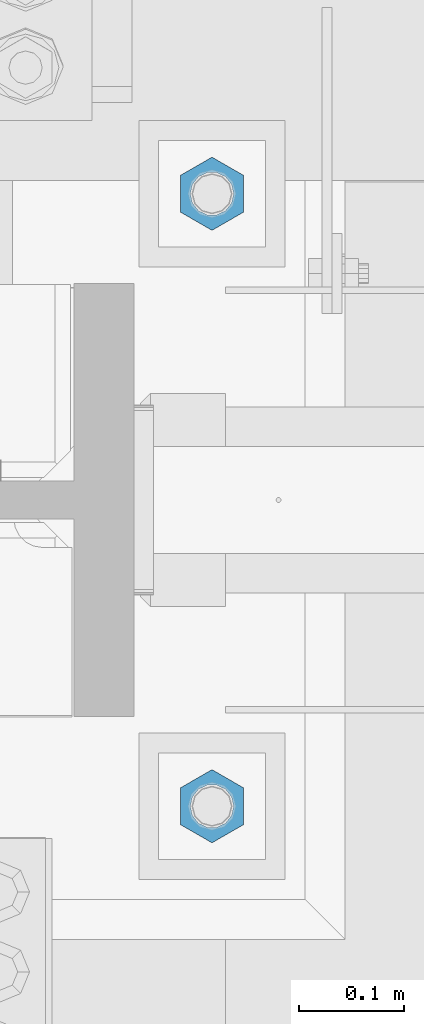
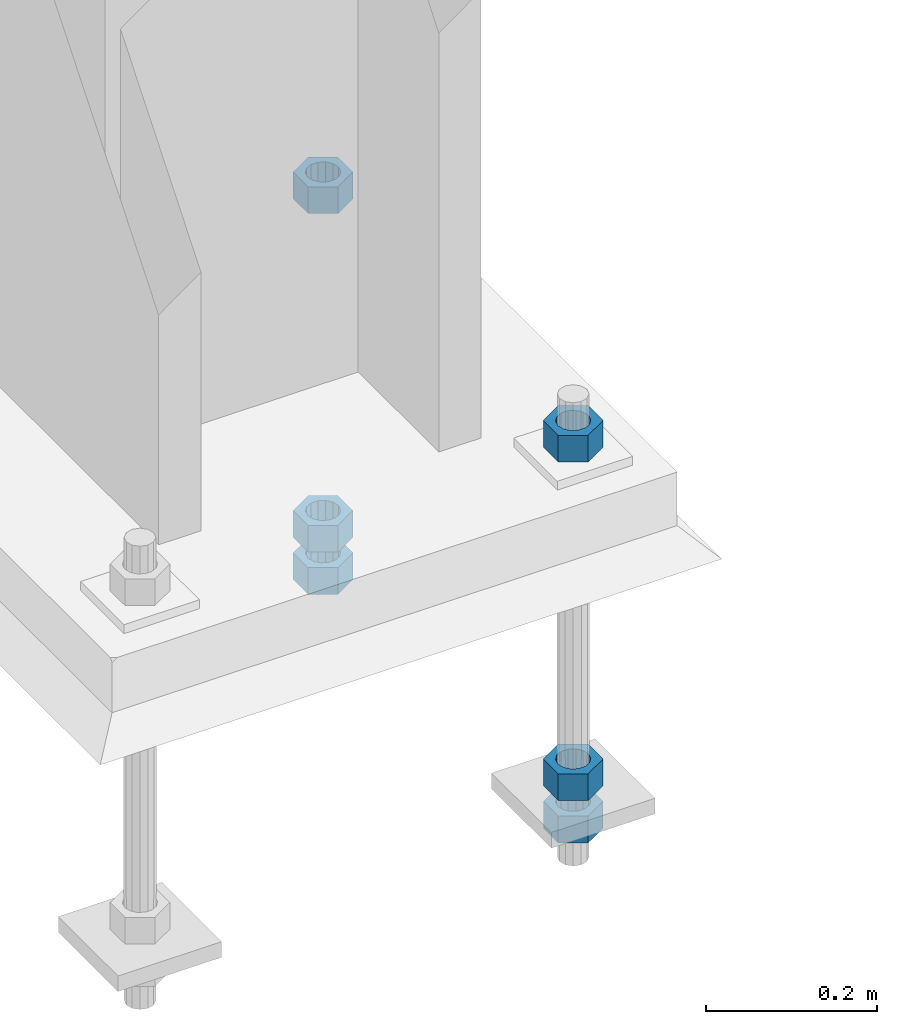
# One storey, part 1731 of 3843: 6 columns, 1 element without a shape of its own.
"""IFC2X3 building model written with IfcOpenShell, lengths in millimetres."""

import ifcopenshell
import ifcopenshell.guid

model = None  # the IFC model being written
_history = None  # IfcOwnerHistory: only IFC2X3 demands one
_inside = {}  # id of a spatial element -> (the spatial element, [elements in it])
_under = {}  # id of a project, library or spatial element -> (it, [spatial elements below it])
_declared = {}  # id of a project -> (the project, [libraries it declares])
_typed = {}  # id of a type object -> (the type object, [elements of that type])
_made_of = {}  # id of a material, layer set ... -> (it, [elements and type objects made of it])


def new_model(schema):
    """Start an empty IFC model of exactly this schema.

    Asked for "IFC4X3", IfcOpenShell would pick the latest addendum, in which some entities
    have other attributes; the version numbers below select the first issue.
    IFC2X3 requires an IfcOwnerHistory on every rooted entity: one is made here for all.
    """
    global model, _history
    if schema == "IFC4X3":
        model = ifcopenshell.file(schema_version=(4, 3, 0, 0))
    else:
        model = ifcopenshell.file(schema=schema)
    _inside.clear()
    _under.clear()
    _declared.clear()
    _typed.clear()
    _made_of.clear()
    _history = None
    if model.schema == "IFC2X3":
        org = make("IfcOrganization", Name="unknown")
        user = make(
            "IfcPersonAndOrganization",
            ThePerson=make("IfcPerson", FamilyName="unknown"),
            TheOrganization=org,
        )
        app = make(
            "IfcApplication",
            ApplicationDeveloper=org,
            Version="unknown",
            ApplicationFullName="unknown",
            ApplicationIdentifier="unknown",
        )
        _history = make(
            "IfcOwnerHistory",
            OwningUser=user,
            OwningApplication=app,
            ChangeAction="ADDED",
            CreationDate=0,
        )
    return model


def make(cls, **values):
    """One entity of the class cls with the attributes given. An attribute that is None is left unset."""
    return model.create_entity(
        cls, **{name: value for name, value in values.items() if value is not None}
    )


def rooted(cls, **values):
    """An entity with a GlobalId (a new one), such as an element, a storey or a relation."""
    return make(cls, GlobalId=ifcopenshell.guid.new(), OwnerHistory=_history, **values)


def si_unit(unit_type, name, prefix=None):
    """IfcSIUnit, for example si_unit("LENGTHUNIT", "METRE", prefix="MILLI")."""
    return make("IfcSIUnit", UnitType=unit_type, Prefix=prefix, Name=name)


def assignment(units):
    """IfcUnitAssignment: the units of a project."""
    return None if units is None else make("IfcUnitAssignment", Units=units)


def point(xyz):
    """IfcCartesianPoint."""
    return None if xyz is None else make("IfcCartesianPoint", Coordinates=xyz)


def direction(xyz):
    """IfcDirection."""
    return None if xyz is None else make("IfcDirection", DirectionRatios=xyz)


def frame(location, z_axis=None, x_axis=None):
    """IfcAxis2Placement3D, a coordinate frame: its origin and axes. An axis left out is left unset."""
    return make(
        "IfcAxis2Placement3D",
        Location=point(location),
        Axis=direction(z_axis),
        RefDirection=direction(x_axis),
    )


def origin_with_axes():
    """The frame at (0, 0, 0) with the z axis (0, 0, 1) and the x axis (1, 0, 0) written out."""
    return frame((0.0, 0.0, 0.0), z_axis=(0.0, 0.0, 1.0), x_axis=(1.0, 0.0, 0.0))


def place(relative_to, where):
    """IfcLocalPlacement: puts the frame where relative to a parent placement (None: the world)."""
    return make(
        "IfcLocalPlacement", PlacementRelTo=relative_to, RelativePlacement=where
    )


def context(
    kind, dimensions, precision=None, world=None, true_north=None, identifier=None
):
    """IfcGeometricRepresentationContext, for example the 3D "Model" context."""
    return make(
        "IfcGeometricRepresentationContext",
        ContextIdentifier=identifier,
        ContextType=kind,
        CoordinateSpaceDimension=dimensions,
        Precision=precision,
        WorldCoordinateSystem=world,
        TrueNorth=true_north,
    )


def subcontext(parent, identifier, kind, view, scale=None):
    """IfcGeometricRepresentationSubContext, for example "Body" below "Model"."""
    return make(
        "IfcGeometricRepresentationSubContext",
        ContextIdentifier=identifier,
        ContextType=kind,
        ParentContext=parent,
        TargetScale=scale,
        TargetView=view,
    )


def project(units=None, contexts=None):
    """IfcProject with its units and contexts."""
    return rooted(
        "IfcProject",
        Name="project",
        RepresentationContexts=contexts,
        UnitsInContext=assignment(units),
    )


def spatial(cls, under=None, at=None, **own):
    """A site, building, storey or space (cls), placed at a placement, below another one or the project."""
    s = rooted(cls, ObjectPlacement=at, **own)
    if under is not None:
        _under.setdefault(under.id(), (under, []))[1].append(s)
    return s


def faces_of(points, faces, orient=None, outer=None):
    """IfcFace entities. A face is a list of loops; a loop is a list of indices into points, from 0.

    orient and outer hold one flag for each loop. By default every Orientation is true, the
    first loop of a face is its IfcFaceOuterBound and the others are IfcFaceBound.
    """
    made = []
    for i, loops in enumerate(faces):
        bounds = []
        for j, loop in enumerate(loops):
            is_outer = j == 0 if outer is None else outer[i][j]
            bounds.append(
                make(
                    "IfcFaceOuterBound" if is_outer else "IfcFaceBound",
                    Bound=make("IfcPolyLoop", Polygon=[points[k] for k in loop]),
                    Orientation=True if orient is None else orient[i][j],
                )
            )
        made.append(make("IfcFace", Bounds=bounds))
    return made


def faceted_brep(points, faces, orient=None, outer=None, voids=None):
    """IfcFacetedBrep: a solid bounded by flat faces; with voids (closed shells), ...WithVoids."""
    shared = [point(p) for p in points]
    hull = make("IfcClosedShell", CfsFaces=faces_of(shared, faces, orient, outer))
    if voids is None:
        return make("IfcFacetedBrep", Outer=hull)
    return make(
        "IfcFacetedBrepWithVoids",
        Outer=hull,
        Voids=[
            make(cls, CfsFaces=faces_of(shared, fs, o, b)) for cls, fs, o, b in voids
        ],
    )


def shape(context_of_items, identifier, shape_type, items):
    """IfcShapeRepresentation: the items that make up one representation, for example the "Body"."""
    return make(
        "IfcShapeRepresentation",
        ContextOfItems=context_of_items,
        RepresentationIdentifier=identifier,
        RepresentationType=shape_type,
        Items=items,
    )


def material(Name=None, Category=None):
    """IfcMaterial."""
    return make("IfcMaterial", Name=Name, Category=Category)


def made_of(thing, what):
    """Note that an element or type object is made of a material, layer set ...; save() writes the relation."""
    if what is not None:
        _made_of.setdefault(what.id(), (what, []))[1].append(thing)
    return thing


def type_object(cls, material=None, **own):
    """A type object (cls), such as IfcWallType, which elements share."""
    return made_of(rooted(cls, **own), material)


def element(
    cls,
    number,
    at=None,
    inside=None,
    cuts=None,
    type_object=None,
    material=None,
    context=None,
    identifier="Body",
    shape_type=None,
    held_by="IfcProductDefinitionShape",
    body=None,
    shapes=None,
    **own,
):
    """One element of the class cls, such as IfcWall. Its Tag is "e" and its number.

    at: its placement. inside: the storey or other place that contains it. cuts: it is an
    opening in that element (IfcRelVoidsElement). A single representation is given by context,
    identifier, shape_type and body (its items); several are given by shapes. held_by: the class
    of the entity that holds the representations. save() writes the other relations.
    """
    e = rooted(cls, Tag="e%d" % number, ObjectPlacement=at, **own)
    if body is not None:
        shapes = [shape(context, identifier, shape_type, body)]
    if shapes is not None:
        e.Representation = make(held_by, Representations=shapes)
    if inside is not None:
        _inside.setdefault(inside.id(), (inside, []))[1].append(e)
    if cuts is not None:
        rooted(
            "IfcRelVoidsElement", RelatingBuildingElement=cuts, RelatedOpeningElement=e
        )
    if type_object is not None:
        _typed.setdefault(type_object.id(), (type_object, []))[1].append(e)
    return made_of(e, material)


def aggregate(whole, parts):
    """IfcRelAggregates: a whole, such as a stair, and the parts it consists of."""
    return rooted("IfcRelAggregates", RelatingObject=whole, RelatedObjects=parts)


def save(model, path):
    """Write the relations noted so far, then the file.

    IfcRelAggregates (storeys below a building ...), IfcRelContainedInSpatialStructure (elements
    in a storey), IfcRelDefinesByType, IfcRelAssociatesMaterial and IfcRelDeclares: one each for
    every whole, place, type object, material and project.
    """
    for whole, parts in _under.values():
        aggregate(whole, parts)
    for where, things in _inside.values():
        rooted(
            "IfcRelContainedInSpatialStructure",
            RelatedElements=things,
            RelatingStructure=where,
        )
    for kind, things in _typed.values():
        rooted("IfcRelDefinesByType", RelatedObjects=things, RelatingType=kind)
    for what, things in _made_of.values():
        rooted("IfcRelAssociatesMaterial", RelatedObjects=things, RelatingMaterial=what)
    for by, libraries in _declared.values():
        rooted("IfcRelDeclares", RelatingContext=by, RelatedDefinitions=libraries)
    model.write(path)


model = new_model("IFC2X3")

# Units and contexts
model_context = context("Model", 3, precision=1e-05, world=origin_with_axes())
body_context = subcontext(model_context, "Body", "Model", "MODEL_VIEW")
ifc_project = project(units=[si_unit("LENGTHUNIT", "METRE", prefix="MILLI"), si_unit("AREAUNIT", "SQUARE_METRE"), si_unit("VOLUMEUNIT", "CUBIC_METRE"), si_unit("MASSUNIT", "GRAM", prefix="KILO"), si_unit("TIMEUNIT", "SECOND"), si_unit("PLANEANGLEUNIT", "RADIAN"), si_unit("SOLIDANGLEUNIT", "STERADIAN"), si_unit("THERMODYNAMICTEMPERATUREUNIT", "DEGREE_CELSIUS"), si_unit("LUMINOUSINTENSITYUNIT", "LUMEN")], contexts=[model_context])

# Site, building, storey
site_placement = place(None, origin_with_axes())
site = spatial("IfcSite", under=ifc_project, at=site_placement, CompositionType="ELEMENT")
building_placement = place(site_placement, origin_with_axes())
building = spatial("IfcBuilding", under=site, at=building_placement, Name="Undefined", CompositionType="ELEMENT")
storey_placement = place(building_placement, origin_with_axes())
storey = spatial("IfcBuildingStorey", under=building, at=storey_placement, Name="Undefined", CompositionType="ELEMENT", Elevation=0.0)

# Assembly, columns
assembly_placement = place(storey_placement, origin_with_axes())
assembly = element("IfcElementAssembly", 1, at=assembly_placement, inside=storey, Name="TEMPLATE", AssemblyPlace="NOTDEFINED", PredefinedType="RIGID_FRAME")
ifc_material = material(Name="STEEL/A572-50")
column_type = type_object("IfcColumnType", Name="1-1/2_HEAVY_HEX_NUT", PredefinedType="NOTDEFINED")
column_1_placement = place(assembly_placement, frame((85940.9, 28422.6, 29705.3), z_axis=(1.0, 0.0, 0.0), x_axis=(0.0, 0.0, -1.0)))
column_1 = element("IfcColumn", 2, at=column_1_placement, type_object=column_type, material=ifc_material, Name="NUT", ObjectType="1-1/2_HEAVY_HEX_NUT", context=body_context, shape_type="Brep", body=[
    faceted_brep([(0.0, -34.9199981689453, 0.0), (0.0, -17.4599990844727, -30.25), (38.0999999999985, -17.4599990844727, -30.25), (38.0999999999985, -34.9199981689453, 0.0), (0.0, 17.4599990844727, -30.25), (38.0999999999985, 17.4599990844727, -30.25), (0.0, 34.9199981689453, 0.0), (38.0999999999985, 34.9199981689453, 0.0), (0.0, 17.4599990844727, 30.25), (38.0999999999985, 17.4599990844727, 30.25), (0.0, -17.4599990844727, 30.25), (38.0999999999985, -17.4599990844727, 30.25), (0.0, 0.0, 20.6399993896484), (0.0, 8.9553601105581, 18.5959968835959), (38.0999999999985, 8.9553601105581, 18.5959968835959), (38.0999999999985, 0.0, 20.6399993896484), (0.0, 16.1370013209525, 12.8688291298167), (38.0999999999985, 16.1370013209525, 12.8688291298167), (0.0, 20.1225115123816, 4.59283194104501), (38.0999999999985, 20.1225115123816, 4.59283194104501), (0.0, 20.1225115123816, -4.59283194104501), (38.0999999999985, 20.1225115123816, -4.59283194104501), (0.0, 16.1370013209525, -12.8688291298167), (38.0999999999985, 16.1370013209525, -12.8688291298167), (0.0, 8.9553601105581, -18.5959968835959), (38.0999999999985, 8.9553601105581, -18.5959968835959), (0.0, 0.0, -20.6399993896484), (38.0999999999985, 0.0, -20.6399993896484), (0.0, -8.9553601105581, -18.5959968835959), (38.0999999999985, -8.9553601105581, -18.5959968835959), (0.0, -16.1370013209525, -12.8688291298167), (38.0999999999985, -16.1370013209525, -12.8688291298167), (0.0, -20.1225115123816, -4.59283194104501), (38.0999999999985, -20.1225115123816, -4.59283194104501), (0.0, -20.1225115123816, 4.59283194104501), (38.0999999999985, -20.1225115123816, 4.59283194104501), (0.0, -16.1370013209525, 12.8688291298167), (38.0999999999985, -16.1370013209525, 12.8688291298167), (0.0, -8.9553601105581, 18.5959968835959), (38.0999999999985, -8.9553601105581, 18.5959968835959)], [[[0, 1, 2, 3]], [[1, 4, 5, 2]], [[4, 6, 7, 5]], [[6, 8, 9, 7]], [[8, 10, 11, 9]], [[10, 0, 3, 11]], [[12, 13, 14, 15]], [[13, 16, 17, 14]], [[16, 18, 19, 17]], [[18, 20, 21, 19]], [[20, 22, 23, 21]], [[22, 24, 25, 23]], [[24, 26, 27, 25]], [[26, 28, 29, 27]], [[28, 30, 31, 29]], [[30, 32, 33, 31]], [[32, 34, 35, 33]], [[34, 36, 37, 35]], [[36, 38, 39, 37]], [[38, 12, 15, 39]], [[5, 7, 9, 11, 3, 2], [17, 19, 21, 23, 25, 27, 29, 31, 33, 35, 37, 39, 15, 14]], [[10, 8, 6, 4, 1, 0], [38, 36, 34, 32, 30, 28, 26, 24, 22, 20, 18, 16, 13, 12]]]),
])
column_2_placement = place(assembly_placement, frame((85940.9, 29006.8, 29705.3), z_axis=(-1.0, 0.0, 0.0), x_axis=(0.0, 0.0, -1.0)))
column_2 = element("IfcColumn", 3, at=column_2_placement, type_object=column_type, material=ifc_material, Name="NUT", ObjectType="1-1/2_HEAVY_HEX_NUT", context=body_context, shape_type="Brep", body=[
    faceted_brep([(0.0, -34.9199981689453, 0.0), (0.0, -17.4599990844727, -30.25), (38.0999999999985, -17.4599990844727, -30.25), (38.0999999999985, -34.9199981689453, 0.0), (0.0, 17.4599990844727, -30.25), (38.0999999999985, 17.4599990844727, -30.25), (0.0, 34.9199981689453, 0.0), (38.0999999999985, 34.9199981689453, 0.0), (0.0, 17.4599990844727, 30.25), (38.0999999999985, 17.4599990844727, 30.25), (0.0, -17.4599990844727, 30.25), (38.0999999999985, -17.4599990844727, 30.25), (0.0, 0.0, 20.6399993896484), (0.0, 8.9553601105581, 18.5959968835959), (38.0999999999985, 8.9553601105581, 18.5959968835959), (38.0999999999985, 0.0, 20.6399993896484), (0.0, 16.1370013209525, 12.8688291298167), (38.0999999999985, 16.1370013209525, 12.8688291298167), (0.0, 20.1225115123816, 4.59283194104501), (38.0999999999985, 20.1225115123816, 4.59283194104501), (0.0, 20.1225115123816, -4.59283194104501), (38.0999999999985, 20.1225115123816, -4.59283194104501), (0.0, 16.1370013209525, -12.8688291298167), (38.0999999999985, 16.1370013209525, -12.8688291298167), (0.0, 8.9553601105581, -18.5959968835959), (38.0999999999985, 8.9553601105581, -18.5959968835959), (0.0, 0.0, -20.6399993896484), (38.0999999999985, 0.0, -20.6399993896484), (0.0, -8.9553601105581, -18.5959968835959), (38.0999999999985, -8.9553601105581, -18.5959968835959), (0.0, -16.1370013209525, -12.8688291298167), (38.0999999999985, -16.1370013209525, -12.8688291298167), (0.0, -20.1225115123816, -4.59283194104501), (38.0999999999985, -20.1225115123816, -4.59283194104501), (0.0, -20.1225115123816, 4.59283194104501), (38.0999999999985, -20.1225115123816, 4.59283194104501), (0.0, -16.1370013209525, 12.8688291298167), (38.0999999999985, -16.1370013209525, 12.8688291298167), (0.0, -8.9553601105581, 18.5959968835959), (38.0999999999985, -8.9553601105581, 18.5959968835959)], [[[0, 1, 2, 3]], [[1, 4, 5, 2]], [[4, 6, 7, 5]], [[6, 8, 9, 7]], [[8, 10, 11, 9]], [[10, 0, 3, 11]], [[12, 13, 14, 15]], [[13, 16, 17, 14]], [[16, 18, 19, 17]], [[18, 20, 21, 19]], [[20, 22, 23, 21]], [[22, 24, 25, 23]], [[24, 26, 27, 25]], [[26, 28, 29, 27]], [[28, 30, 31, 29]], [[30, 32, 33, 31]], [[32, 34, 35, 33]], [[34, 36, 37, 35]], [[36, 38, 39, 37]], [[38, 12, 15, 39]], [[5, 7, 9, 11, 3, 2], [17, 19, 21, 23, 25, 27, 29, 31, 33, 35, 37, 39, 15, 14]], [[10, 8, 6, 4, 1, 0], [38, 36, 34, 32, 30, 28, 26, 24, 22, 20, 18, 16, 13, 12]]]),
])
column_3_placement = place(assembly_placement, frame((85940.9, 28422.6, 30187.9), z_axis=(1.0, 0.0, 0.0), x_axis=(0.0, 0.0, -1.0)))
column_3 = element("IfcColumn", 4, at=column_3_placement, type_object=column_type, material=ifc_material, Name="NUT", ObjectType="1-1/2_HEAVY_HEX_NUT", context=body_context, shape_type="Brep", body=[
    faceted_brep([(0.0, -34.9199981689453, 0.0), (0.0, -17.4599990844727, -30.25), (38.0999999999985, -17.4599990844727, -30.25), (38.0999999999985, -34.9199981689453, 0.0), (0.0, 17.4599990844727, -30.25), (38.0999999999985, 17.4599990844727, -30.25), (0.0, 34.9199981689453, 0.0), (38.0999999999985, 34.9199981689453, 0.0), (0.0, 17.4599990844727, 30.25), (38.0999999999985, 17.4599990844727, 30.25), (0.0, -17.4599990844727, 30.25), (38.0999999999985, -17.4599990844727, 30.25), (0.0, 0.0, 20.6399993896484), (0.0, 8.9553601105581, 18.5959968835959), (38.0999999999985, 8.9553601105581, 18.5959968835959), (38.0999999999985, 0.0, 20.6399993896484), (0.0, 16.1370013209525, 12.8688291298167), (38.0999999999985, 16.1370013209525, 12.8688291298167), (0.0, 20.1225115123816, 4.59283194104501), (38.0999999999985, 20.1225115123816, 4.59283194104501), (0.0, 20.1225115123816, -4.59283194104501), (38.0999999999985, 20.1225115123816, -4.59283194104501), (0.0, 16.1370013209525, -12.8688291298167), (38.0999999999985, 16.1370013209525, -12.8688291298167), (0.0, 8.9553601105581, -18.5959968835959), (38.0999999999985, 8.9553601105581, -18.5959968835959), (0.0, 0.0, -20.6399993896484), (38.0999999999985, 0.0, -20.6399993896484), (0.0, -8.9553601105581, -18.5959968835959), (38.0999999999985, -8.9553601105581, -18.5959968835959), (0.0, -16.1370013209525, -12.8688291298167), (38.0999999999985, -16.1370013209525, -12.8688291298167), (0.0, -20.1225115123816, -4.59283194104501), (38.0999999999985, -20.1225115123816, -4.59283194104501), (0.0, -20.1225115123816, 4.59283194104501), (38.0999999999985, -20.1225115123816, 4.59283194104501), (0.0, -16.1370013209525, 12.8688291298167), (38.0999999999985, -16.1370013209525, 12.8688291298167), (0.0, -8.9553601105581, 18.5959968835959), (38.0999999999985, -8.9553601105581, 18.5959968835959)], [[[0, 1, 2, 3]], [[1, 4, 5, 2]], [[4, 6, 7, 5]], [[6, 8, 9, 7]], [[8, 10, 11, 9]], [[10, 0, 3, 11]], [[12, 13, 14, 15]], [[13, 16, 17, 14]], [[16, 18, 19, 17]], [[18, 20, 21, 19]], [[20, 22, 23, 21]], [[22, 24, 25, 23]], [[24, 26, 27, 25]], [[26, 28, 29, 27]], [[28, 30, 31, 29]], [[30, 32, 33, 31]], [[32, 34, 35, 33]], [[34, 36, 37, 35]], [[36, 38, 39, 37]], [[38, 12, 15, 39]], [[5, 7, 9, 11, 3, 2], [17, 19, 21, 23, 25, 27, 29, 31, 33, 35, 37, 39, 15, 14]], [[10, 8, 6, 4, 1, 0], [38, 36, 34, 32, 30, 28, 26, 24, 22, 20, 18, 16, 13, 12]]]),
])
column_4_placement = place(assembly_placement, frame((85940.9, 28422.6, 29644.975), z_axis=(1.0, 0.0, 0.0), x_axis=(0.0, 0.0, -1.0)))
column_4 = element("IfcColumn", 5, at=column_4_placement, type_object=column_type, material=ifc_material, Name="NUT", ObjectType="1-1/2_HEAVY_HEX_NUT", context=body_context, shape_type="Brep", body=[
    faceted_brep([(0.0, -34.9199981689453, 0.0), (0.0, -17.4599990844727, -30.25), (38.0999999999985, -17.4599990844727, -30.25), (38.0999999999985, -34.9199981689453, 0.0), (0.0, 17.4599990844727, -30.25), (38.0999999999985, 17.4599990844727, -30.25), (0.0, 34.9199981689453, 0.0), (38.0999999999985, 34.9199981689453, 0.0), (0.0, 17.4599990844727, 30.25), (38.0999999999985, 17.4599990844727, 30.25), (0.0, -17.4599990844727, 30.25), (38.0999999999985, -17.4599990844727, 30.25), (0.0, 0.0, 20.6399993896484), (0.0, 8.9553601105581, 18.5959968835959), (38.0999999999985, 8.9553601105581, 18.5959968835959), (38.0999999999985, 0.0, 20.6399993896484), (0.0, 16.1370013209525, 12.8688291298167), (38.0999999999985, 16.1370013209525, 12.8688291298167), (0.0, 20.1225115123816, 4.59283194104501), (38.0999999999985, 20.1225115123816, 4.59283194104501), (0.0, 20.1225115123816, -4.59283194104501), (38.0999999999985, 20.1225115123816, -4.59283194104501), (0.0, 16.1370013209525, -12.8688291298167), (38.0999999999985, 16.1370013209525, -12.8688291298167), (0.0, 8.9553601105581, -18.5959968835959), (38.0999999999985, 8.9553601105581, -18.5959968835959), (0.0, 0.0, -20.6399993896484), (38.0999999999985, 0.0, -20.6399993896484), (0.0, -8.9553601105581, -18.5959968835959), (38.0999999999985, -8.9553601105581, -18.5959968835959), (0.0, -16.1370013209525, -12.8688291298167), (38.0999999999985, -16.1370013209525, -12.8688291298167), (0.0, -20.1225115123816, -4.59283194104501), (38.0999999999985, -20.1225115123816, -4.59283194104501), (0.0, -20.1225115123816, 4.59283194104501), (38.0999999999985, -20.1225115123816, 4.59283194104501), (0.0, -16.1370013209525, 12.8688291298167), (38.0999999999985, -16.1370013209525, 12.8688291298167), (0.0, -8.9553601105581, 18.5959968835959), (38.0999999999985, -8.9553601105581, 18.5959968835959)], [[[0, 1, 2, 3]], [[1, 4, 5, 2]], [[4, 6, 7, 5]], [[6, 8, 9, 7]], [[8, 10, 11, 9]], [[10, 0, 3, 11]], [[12, 13, 14, 15]], [[13, 16, 17, 14]], [[16, 18, 19, 17]], [[18, 20, 21, 19]], [[20, 22, 23, 21]], [[22, 24, 25, 23]], [[24, 26, 27, 25]], [[26, 28, 29, 27]], [[28, 30, 31, 29]], [[30, 32, 33, 31]], [[32, 34, 35, 33]], [[34, 36, 37, 35]], [[36, 38, 39, 37]], [[38, 12, 15, 39]], [[5, 7, 9, 11, 3, 2], [17, 19, 21, 23, 25, 27, 29, 31, 33, 35, 37, 39, 15, 14]], [[10, 8, 6, 4, 1, 0], [38, 36, 34, 32, 30, 28, 26, 24, 22, 20, 18, 16, 13, 12]]]),
])
column_5_placement = place(assembly_placement, frame((85940.9, 29006.8, 30187.9), z_axis=(-1.0, 0.0, 0.0), x_axis=(0.0, 0.0, -1.0)))
column_5 = element("IfcColumn", 6, at=column_5_placement, type_object=column_type, material=ifc_material, Name="NUT", ObjectType="1-1/2_HEAVY_HEX_NUT", context=body_context, shape_type="Brep", body=[
    faceted_brep([(0.0, -34.9199981689453, 0.0), (0.0, -17.4599990844727, -30.25), (38.0999999999985, -17.4599990844727, -30.25), (38.0999999999985, -34.9199981689453, 0.0), (0.0, 17.4599990844727, -30.25), (38.0999999999985, 17.4599990844727, -30.25), (0.0, 34.9199981689453, 0.0), (38.0999999999985, 34.9199981689453, 0.0), (0.0, 17.4599990844727, 30.25), (38.0999999999985, 17.4599990844727, 30.25), (0.0, -17.4599990844727, 30.25), (38.0999999999985, -17.4599990844727, 30.25), (0.0, 0.0, 20.6399993896484), (0.0, 8.9553601105581, 18.5959968835959), (38.0999999999985, 8.9553601105581, 18.5959968835959), (38.0999999999985, 0.0, 20.6399993896484), (0.0, 16.1370013209525, 12.8688291298167), (38.0999999999985, 16.1370013209525, 12.8688291298167), (0.0, 20.1225115123816, 4.59283194104501), (38.0999999999985, 20.1225115123816, 4.59283194104501), (0.0, 20.1225115123816, -4.59283194104501), (38.0999999999985, 20.1225115123816, -4.59283194104501), (0.0, 16.1370013209525, -12.8688291298167), (38.0999999999985, 16.1370013209525, -12.8688291298167), (0.0, 8.9553601105581, -18.5959968835959), (38.0999999999985, 8.9553601105581, -18.5959968835959), (0.0, 0.0, -20.6399993896484), (38.0999999999985, 0.0, -20.6399993896484), (0.0, -8.9553601105581, -18.5959968835959), (38.0999999999985, -8.9553601105581, -18.5959968835959), (0.0, -16.1370013209525, -12.8688291298167), (38.0999999999985, -16.1370013209525, -12.8688291298167), (0.0, -20.1225115123816, -4.59283194104501), (38.0999999999985, -20.1225115123816, -4.59283194104501), (0.0, -20.1225115123816, 4.59283194104501), (38.0999999999985, -20.1225115123816, 4.59283194104501), (0.0, -16.1370013209525, 12.8688291298167), (38.0999999999985, -16.1370013209525, 12.8688291298167), (0.0, -8.9553601105581, 18.5959968835959), (38.0999999999985, -8.9553601105581, 18.5959968835959)], [[[0, 1, 2, 3]], [[1, 4, 5, 2]], [[4, 6, 7, 5]], [[6, 8, 9, 7]], [[8, 10, 11, 9]], [[10, 0, 3, 11]], [[12, 13, 14, 15]], [[13, 16, 17, 14]], [[16, 18, 19, 17]], [[18, 20, 21, 19]], [[20, 22, 23, 21]], [[22, 24, 25, 23]], [[24, 26, 27, 25]], [[26, 28, 29, 27]], [[28, 30, 31, 29]], [[30, 32, 33, 31]], [[32, 34, 35, 33]], [[34, 36, 37, 35]], [[36, 38, 39, 37]], [[38, 12, 15, 39]], [[5, 7, 9, 11, 3, 2], [17, 19, 21, 23, 25, 27, 29, 31, 33, 35, 37, 39, 15, 14]], [[10, 8, 6, 4, 1, 0], [38, 36, 34, 32, 30, 28, 26, 24, 22, 20, 18, 16, 13, 12]]]),
])
column_6_placement = place(assembly_placement, frame((85940.9, 29006.8, 29644.975), z_axis=(-1.0, 0.0, 0.0), x_axis=(0.0, 0.0, -1.0)))
column_6 = element("IfcColumn", 7, at=column_6_placement, type_object=column_type, material=ifc_material, Name="NUT", ObjectType="1-1/2_HEAVY_HEX_NUT", context=body_context, shape_type="Brep", body=[
    faceted_brep([(0.0, -34.9199981689453, 0.0), (0.0, -17.4599990844727, -30.25), (38.0999999999985, -17.4599990844727, -30.25), (38.0999999999985, -34.9199981689453, 0.0), (0.0, 17.4599990844727, -30.25), (38.0999999999985, 17.4599990844727, -30.25), (0.0, 34.9199981689453, 0.0), (38.0999999999985, 34.9199981689453, 0.0), (0.0, 17.4599990844727, 30.25), (38.0999999999985, 17.4599990844727, 30.25), (0.0, -17.4599990844727, 30.25), (38.0999999999985, -17.4599990844727, 30.25), (0.0, 0.0, 20.6399993896484), (0.0, 8.9553601105581, 18.5959968835959), (38.0999999999985, 8.9553601105581, 18.5959968835959), (38.0999999999985, 0.0, 20.6399993896484), (0.0, 16.1370013209525, 12.8688291298167), (38.0999999999985, 16.1370013209525, 12.8688291298167), (0.0, 20.1225115123816, 4.59283194104501), (38.0999999999985, 20.1225115123816, 4.59283194104501), (0.0, 20.1225115123816, -4.59283194104501), (38.0999999999985, 20.1225115123816, -4.59283194104501), (0.0, 16.1370013209525, -12.8688291298167), (38.0999999999985, 16.1370013209525, -12.8688291298167), (0.0, 8.9553601105581, -18.5959968835959), (38.0999999999985, 8.9553601105581, -18.5959968835959), (0.0, 0.0, -20.6399993896484), (38.0999999999985, 0.0, -20.6399993896484), (0.0, -8.9553601105581, -18.5959968835959), (38.0999999999985, -8.9553601105581, -18.5959968835959), (0.0, -16.1370013209525, -12.8688291298167), (38.0999999999985, -16.1370013209525, -12.8688291298167), (0.0, -20.1225115123816, -4.59283194104501), (38.0999999999985, -20.1225115123816, -4.59283194104501), (0.0, -20.1225115123816, 4.59283194104501), (38.0999999999985, -20.1225115123816, 4.59283194104501), (0.0, -16.1370013209525, 12.8688291298167), (38.0999999999985, -16.1370013209525, 12.8688291298167), (0.0, -8.9553601105581, 18.5959968835959), (38.0999999999985, -8.9553601105581, 18.5959968835959)], [[[0, 1, 2, 3]], [[1, 4, 5, 2]], [[4, 6, 7, 5]], [[6, 8, 9, 7]], [[8, 10, 11, 9]], [[10, 0, 3, 11]], [[12, 13, 14, 15]], [[13, 16, 17, 14]], [[16, 18, 19, 17]], [[18, 20, 21, 19]], [[20, 22, 23, 21]], [[22, 24, 25, 23]], [[24, 26, 27, 25]], [[26, 28, 29, 27]], [[28, 30, 31, 29]], [[30, 32, 33, 31]], [[32, 34, 35, 33]], [[34, 36, 37, 35]], [[36, 38, 39, 37]], [[38, 12, 15, 39]], [[5, 7, 9, 11, 3, 2], [17, 19, 21, 23, 25, 27, 29, 31, 33, 35, 37, 39, 15, 14]], [[10, 8, 6, 4, 1, 0], [38, 36, 34, 32, 30, 28, 26, 24, 22, 20, 18, 16, 13, 12]]]),
])
aggregate(assembly, [column_1, column_2, column_3, column_4, column_5, column_6])

save(model, "model.ifc")
